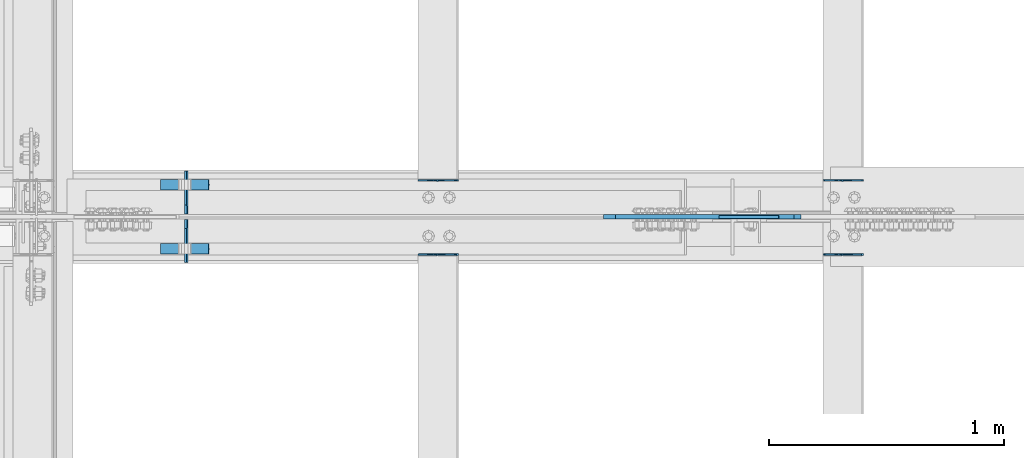
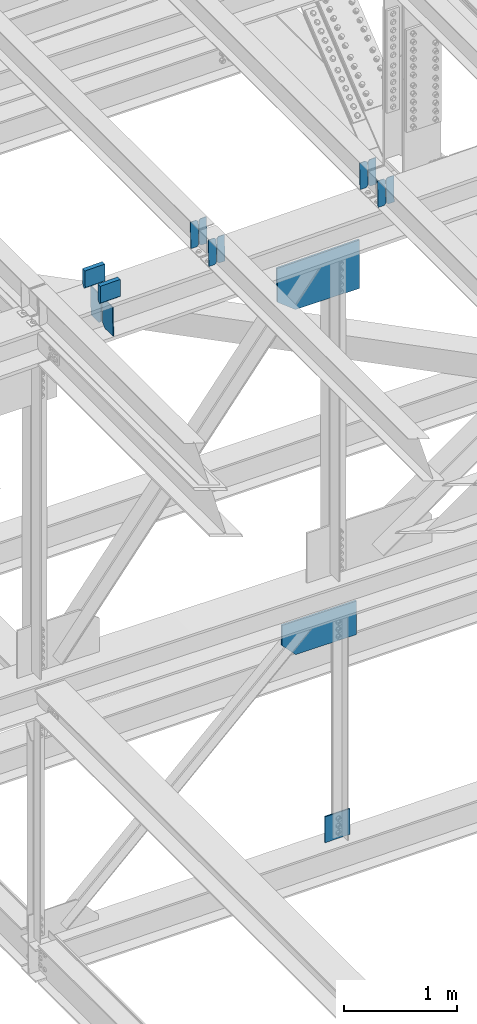
# One storey, part 3597 of 3843: 15 plates, 7 elements without a shape of their own.
"""IFC2X3 building model written with IfcOpenShell, lengths in millimetres."""

from ifc_helpers import new_model, si_unit, frame, origin_with_axes, place, context, subcontext, project, spatial, faceted_brep, material, type_object, element, aggregate, save


model = new_model("IFC2X3")

# Units and contexts
model_context = context("Model", 3, precision=1e-05, world=origin_with_axes())
body_context = subcontext(model_context, "Body", "Model", "MODEL_VIEW")
ifc_project = project(units=[si_unit("LENGTHUNIT", "METRE", prefix="MILLI"), si_unit("AREAUNIT", "SQUARE_METRE"), si_unit("VOLUMEUNIT", "CUBIC_METRE"), si_unit("MASSUNIT", "GRAM", prefix="KILO"), si_unit("TIMEUNIT", "SECOND"), si_unit("PLANEANGLEUNIT", "RADIAN"), si_unit("SOLIDANGLEUNIT", "STERADIAN"), si_unit("THERMODYNAMICTEMPERATUREUNIT", "DEGREE_CELSIUS"), si_unit("LUMINOUSINTENSITYUNIT", "LUMEN")], contexts=[model_context])

# Site, building, storey
site_placement = place(None, origin_with_axes())
site = spatial("IfcSite", under=ifc_project, at=site_placement, CompositionType="ELEMENT")
building_placement = place(site_placement, origin_with_axes())
building = spatial("IfcBuilding", under=site, at=building_placement, Name="Undefined", CompositionType="ELEMENT")
storey_placement = place(building_placement, origin_with_axes())
storey = spatial("IfcBuildingStorey", under=building, at=storey_placement, Name="Undefined", CompositionType="ELEMENT", Elevation=0.0)

# Assembly, plates
assembly_1_placement = place(storey_placement, origin_with_axes())
assembly_1 = element("IfcElementAssembly", 1, at=assembly_1_placement, inside=storey, Name="BEAM", AssemblyPlace="NOTDEFINED", PredefinedType="RIGID_FRAME")
ifc_material = material(Name="STEEL/A572-50")
plate_type_1 = type_object("IfcPlateType", PredefinedType="NOTDEFINED")
plate_1_placement = place(assembly_1_placement, frame((80549.4964783697, 50714.4613259813, 46444.4451197829), z_axis=(-0.021152098138482, -0.000624861000040255, 0.999776074075125), x_axis=(-0.999776269355722, 1.23390000256453e-05, -0.0211520940075457)))
plate_1 = element("IfcPlate", 2, at=plate_1_placement, type_object=plate_type_1, material=ifc_material, Name="PLATE", context=body_context, shape_type="Brep", body=[
    faceted_brep([(0.0, -3.17499999999927, 0.0), (6.83940015733242e-10, -3.17499999996653, 288.924999998613), (6.54836185276508e-10, 3.17500000001746, 288.924999998591), (0.0, 3.17499999999927, 0.0), (60.3250007643655, -3.17500000017753, 288.924999998606), (60.3250007643219, 3.17499999979918, 288.924999998584), (79.3750000013097, -3.17500000025029, 269.875000761494), (79.375000001266, 3.17499999972642, 269.875000761487), (79.375000000713, -3.17500000026484, 19.0499992370605), (79.3750000006985, 3.17499999971187, 19.0499992370533), (60.325000763667, -3.17500000020664, -1.45519152283669e-11), (60.3250007636234, 3.17499999977736, -3.63797880709171e-11)], [[[0, 1, 2, 3]], [[1, 4, 5, 2]], [[4, 6, 7, 5]], [[6, 8, 9, 7]], [[8, 10, 11, 9]], [[10, 0, 3, 11]], [[5, 7, 9, 11, 3, 2]], [[10, 8, 6, 4, 1, 0]]]),
])
plate_2_placement = place(assembly_1_placement, frame((80463.7906576785, 50714.4624592728, 46442.6318565363), z_axis=(-0.021152098138482, -0.000624861000040255, 0.999776074075125), x_axis=(-0.999776269355722, 1.23390000256453e-05, -0.0211520940075457)))
plate_2 = element("IfcPlate", 3, at=plate_2_placement, type_object=plate_type_1, material=ifc_material, Name="PLATE", context=body_context, shape_type="Brep", body=[
    faceted_brep([(4.36557456851006e-11, -3.17499999998836, 19.0499992370969), (6.11180439591408e-10, -3.17499999996653, 269.875000761516), (5.96628524363041e-10, 3.17500000001746, 269.875000761502), (1.45519152283669e-11, 3.17499999998836, 19.0499992370824), (19.0499992376572, -3.17500000003201, 288.924999998606), (19.0499992376281, 3.1749999999447, 288.924999998584), (79.3750000013242, -3.17500000025029, 288.924999998591), (79.3750000013097, 3.1749999997337, 288.92499999857), (79.3750000006548, -3.17500000026484, -2.18278728425503e-11), (79.3750000006403, 3.17499999969732, -2.91038304567337e-11), (19.0499992370023, -3.17500000005384, 0.0), (19.0499992369587, 3.17499999992287, -1.45519152283669e-11)], [[[0, 1, 2, 3]], [[1, 4, 5, 2]], [[4, 6, 7, 5]], [[6, 8, 9, 7]], [[8, 10, 11, 9]], [[10, 0, 3, 11]], [[5, 7, 9, 11, 3, 2]], [[10, 8, 6, 4, 1, 0]]]),
])
aggregate(assembly_1, [plate_1, plate_2])

assembly_2_placement = place(storey_placement, origin_with_axes())
assembly_2 = element("IfcElementAssembly", 4, at=assembly_2_placement, inside=storey, Name="BEAM", AssemblyPlace="NOTDEFINED", PredefinedType="RIGID_FRAME")
plate_3_placement = place(assembly_2_placement, frame((80549.4964783674, 50397.4274850828, 46443.9986155852), z_axis=(-0.0211520975879684, -0.0021646719998389, 0.999773925926638), x_axis=(-0.999776269348977, 4.5491000049241e-05, -0.0211520490073722)))
plate_3 = element("IfcPlate", 5, at=plate_3_placement, type_object=plate_type_1, material=ifc_material, Name="PLATE", context=body_context, shape_type="Brep", body=[
    faceted_brep([(0.0, -3.17499999999927, 0.0), (6.83940015733242e-10, -3.17499999996653, 288.924999998613), (6.54836185276508e-10, 3.17500000001746, 288.924999998591), (0.0, 3.17499999999927, 0.0), (60.3250007643655, -3.17500000017753, 288.924999998606), (60.3250007643219, 3.17499999979918, 288.924999998584), (79.3750000013097, -3.17500000025029, 269.875000761494), (79.375000001266, 3.17499999972642, 269.875000761487), (79.375000000713, -3.17500000026484, 19.0499992370605), (79.3750000006985, 3.17499999971187, 19.0499992370533), (60.325000763667, -3.17500000020664, -1.45519152283669e-11), (60.3250007636234, 3.17499999977736, -3.63797880709171e-11)], [[[0, 1, 2, 3]], [[1, 4, 5, 2]], [[4, 6, 7, 5]], [[6, 8, 9, 7]], [[8, 10, 11, 9]], [[10, 0, 3, 11]], [[5, 7, 9, 11, 3, 2]], [[10, 8, 6, 4, 1, 0]]]),
])
plate_4_placement = place(assembly_2_placement, frame((80463.7906576763, 50397.4314110805, 46442.1853562345), z_axis=(-0.0211520975879684, -0.0021646719998389, 0.999773925926638), x_axis=(-0.999776269348977, 4.5491000049241e-05, -0.0211520490073722)))
plate_4 = element("IfcPlate", 6, at=plate_4_placement, type_object=plate_type_1, material=ifc_material, Name="PLATE", context=body_context, shape_type="Brep", body=[
    faceted_brep([(4.36557456851006e-11, -3.17499999998836, 19.0499992370969), (6.11180439591408e-10, -3.17499999996653, 269.875000761516), (5.96628524363041e-10, 3.17500000001746, 269.875000761502), (1.45519152283669e-11, 3.17499999998836, 19.0499992370824), (19.0499992376572, -3.17500000003201, 288.924999998606), (19.0499992376281, 3.1749999999447, 288.924999998584), (79.3750000013242, -3.17500000025029, 288.924999998591), (79.3750000013097, 3.1749999997337, 288.92499999857), (79.3750000006548, -3.17500000026484, -2.18278728425503e-11), (79.3750000006403, 3.17499999969732, -2.91038304567337e-11), (19.0499992370023, -3.17500000005384, 0.0), (19.0499992369587, 3.17499999992287, -1.45519152283669e-11)], [[[0, 1, 2, 3]], [[1, 4, 5, 2]], [[4, 6, 7, 5]], [[6, 8, 9, 7]], [[8, 10, 11, 9]], [[10, 0, 3, 11]], [[5, 7, 9, 11, 3, 2]], [[10, 8, 6, 4, 1, 0]]]),
])
aggregate(assembly_2, [plate_3, plate_4])

assembly_3_placement = place(storey_placement, origin_with_axes())
assembly_3 = element("IfcElementAssembly", 7, at=assembly_3_placement, inside=storey, Name="BEAM", AssemblyPlace="NOTDEFINED", PredefinedType="RIGID_FRAME")
plate_5_placement = place(assembly_3_placement, frame((78822.2964783698, 50714.4265898309, 46411.4962019354), z_axis=(-0.021152097741724, -0.000508339000058186, 0.99977614011967), x_axis=(-0.999776269357268, 1.0337000006824e-05, -0.0211520950075907)))
plate_5 = element("IfcPlate", 8, at=plate_5_placement, type_object=plate_type_1, material=ifc_material, Name="PLATE", context=body_context, shape_type="Brep", body=[
    faceted_brep([(0.0, -3.17499999999927, 0.0), (6.83940015733242e-10, -3.17499999996653, 288.924999998613), (6.54836185276508e-10, 3.17500000001746, 288.924999998591), (0.0, 3.17499999999927, 0.0), (60.3250007643655, -3.17500000017753, 288.924999998606), (60.3250007643219, 3.17499999979918, 288.924999998584), (79.3750000013097, -3.17500000025029, 269.875000761494), (79.375000001266, 3.17499999972642, 269.875000761487), (79.375000000713, -3.17500000026484, 19.0499992370605), (79.3750000006985, 3.17499999971187, 19.0499992370533), (60.325000763667, -3.17500000020664, -1.45519152283669e-11), (60.3250007636234, 3.17499999977736, -3.63797880709171e-11)], [[[0, 1, 2, 3]], [[1, 4, 5, 2]], [[4, 6, 7, 5]], [[6, 8, 9, 7]], [[8, 10, 11, 9]], [[10, 0, 3, 11]], [[5, 7, 9, 11, 3, 2]], [[10, 8, 6, 4, 1, 0]]]),
])
plate_6_placement = place(assembly_3_placement, frame((78736.5906576785, 50714.4275117894, 46409.6829385691), z_axis=(-0.021152097741724, -0.000508339000058186, 0.99977614011967), x_axis=(-0.999776269357268, 1.0337000006824e-05, -0.0211520950075907)))
plate_6 = element("IfcPlate", 9, at=plate_6_placement, type_object=plate_type_1, material=ifc_material, Name="PLATE", context=body_context, shape_type="Brep", body=[
    faceted_brep([(4.36557456851006e-11, -3.17499999998836, 19.0499992370969), (6.11180439591408e-10, -3.17499999996653, 269.875000761516), (5.96628524363041e-10, 3.17500000001746, 269.875000761502), (1.45519152283669e-11, 3.17499999998836, 19.0499992370824), (19.0499992376572, -3.17500000003201, 288.924999998606), (19.0499992376281, 3.1749999999447, 288.924999998584), (79.3750000013242, -3.17500000025029, 288.924999998591), (79.3750000013097, 3.1749999997337, 288.92499999857), (79.3750000006548, -3.17500000026484, -2.18278728425503e-11), (79.3750000006403, 3.17499999969732, -2.91038304567337e-11), (19.0499992370023, -3.17500000005384, 0.0), (19.0499992369587, 3.17499999992287, -1.45519152283669e-11)], [[[0, 1, 2, 3]], [[1, 4, 5, 2]], [[4, 6, 7, 5]], [[6, 8, 9, 7]], [[8, 10, 11, 9]], [[10, 0, 3, 11]], [[5, 7, 9, 11, 3, 2]], [[10, 8, 6, 4, 1, 0]]]),
])
aggregate(assembly_3, [plate_5, plate_6])

assembly_4_placement = place(storey_placement, origin_with_axes())
assembly_4 = element("IfcElementAssembly", 10, at=assembly_4_placement, inside=storey, Name="BEAM", AssemblyPlace="NOTDEFINED", PredefinedType="RIGID_FRAME")
plate_7_placement = place(assembly_4_placement, frame((78822.2964783705, 50397.4508500042, 46411.0510577697), z_axis=(-0.0211520984925882, -0.00226925499999197, 0.999773693998349), x_axis=(-0.999776269336975, 4.80100000080746e-05, -0.0211520440071395)))
plate_7 = element("IfcPlate", 11, at=plate_7_placement, type_object=plate_type_1, material=ifc_material, Name="PLATE", context=body_context, shape_type="Brep", body=[
    faceted_brep([(0.0, -3.17499999999927, 0.0), (6.83940015733242e-10, -3.17499999996653, 288.924999998613), (6.54836185276508e-10, 3.17500000001746, 288.924999998591), (0.0, 3.17499999999927, 0.0), (60.3250007643655, -3.17500000017753, 288.924999998606), (60.3250007643219, 3.17499999979918, 288.924999998584), (79.3750000013097, -3.17500000025029, 269.875000761494), (79.375000001266, 3.17499999972642, 269.875000761487), (79.375000000713, -3.17500000026484, 19.0499992370605), (79.3750000006985, 3.17499999971187, 19.0499992370533), (60.325000763667, -3.17500000020664, -1.45519152283669e-11), (60.3250007636234, 3.17499999977736, -3.63797880709171e-11)], [[[0, 1, 2, 3]], [[1, 4, 5, 2]], [[4, 6, 7, 5]], [[6, 8, 9, 7]], [[8, 10, 11, 9]], [[10, 0, 3, 11]], [[5, 7, 9, 11, 3, 2]], [[10, 8, 6, 4, 1, 0]]]),
])
plate_8_placement = place(assembly_4_placement, frame((78736.5906576793, 50397.4549656826, 46409.2377988391), z_axis=(-0.0211520984925882, -0.00226925499999197, 0.999773693998349), x_axis=(-0.999776269336975, 4.80100000080746e-05, -0.0211520440071395)))
plate_8 = element("IfcPlate", 12, at=plate_8_placement, type_object=plate_type_1, material=ifc_material, Name="PLATE", context=body_context, shape_type="Brep", body=[
    faceted_brep([(4.36557456851006e-11, -3.17499999998836, 19.0499992370969), (6.11180439591408e-10, -3.17499999996653, 269.875000761516), (5.96628524363041e-10, 3.17500000001746, 269.875000761502), (1.45519152283669e-11, 3.17499999998836, 19.0499992370824), (19.0499992376572, -3.17500000003201, 288.924999998606), (19.0499992376281, 3.1749999999447, 288.924999998584), (79.3750000013242, -3.17500000025029, 288.924999998591), (79.3750000013097, 3.1749999997337, 288.92499999857), (79.3750000006548, -3.17500000026484, -2.18278728425503e-11), (79.3750000006403, 3.17499999969732, -2.91038304567337e-11), (19.0499992370023, -3.17500000005384, 0.0), (19.0499992369587, 3.17499999992287, -1.45519152283669e-11)], [[[0, 1, 2, 3]], [[1, 4, 5, 2]], [[4, 6, 7, 5]], [[6, 8, 9, 7]], [[8, 10, 11, 9]], [[10, 0, 3, 11]], [[5, 7, 9, 11, 3, 2]], [[10, 8, 6, 4, 1, 0]]]),
])
aggregate(assembly_4, [plate_7, plate_8])

assembly_5_placement = place(storey_placement, origin_with_axes())
assembly_5 = element("IfcElementAssembly", 13, at=assembly_5_placement, inside=storey, Name="BEAM", AssemblyPlace="NOTDEFINED", PredefinedType="RIGID_FRAME")
plate_type_2 = type_object("IfcPlateType", PredefinedType="NOTDEFINED")
plate_9_placement = place(assembly_5_placement, frame((77665.5774598296, 50363.1375, 46022.5066891765), z_axis=(-0.0198294219936798, 0.0, 0.99980337768153), x_axis=(0.0, 1.0, 0.0)))
plate_9 = element("IfcPlate", 14, at=plate_9_placement, type_object=plate_type_2, material=ifc_material, Name="PL", context=body_context, shape_type="Brep", body=[
    faceted_brep([(0.0, -4.76249999999709, 0.0), (0.0, -4.76249999986612, 316.896679377329), (0.0, 4.7625000001135, 316.896679377329), (0.0, 4.76249999999709, 0.0), (145.748320007318, -4.76249999986612, 316.896679377329), (145.748320007318, 4.7625000001135, 316.896679377329), (184.149999999994, -4.76249999988067, 278.494999384784), (184.149999999994, 4.76250000009895, 278.494999384777), (184.149999999994, -4.76249999998254, 38.4016799925521), (184.149999999994, 4.76249999999709, 38.4016799925594), (145.748320007318, -4.76249999999709, 7.27595761418343e-12), (145.748320007318, 4.76249999996799, 0.0)], [[[0, 1, 2, 3]], [[1, 4, 5, 2]], [[4, 6, 7, 5]], [[6, 8, 9, 7]], [[8, 10, 11, 9]], [[10, 0, 3, 11]], [[5, 7, 9, 11, 3, 2]], [[10, 8, 6, 4, 1, 0]]]),
])
plate_10_placement = place(assembly_5_placement, frame((77665.5774598296, 50570.1125, 46022.5066891765), z_axis=(-0.0198294219936798, 0.0, 0.99980337768153), x_axis=(0.0, 1.0, 0.0)))
plate_10 = element("IfcPlate", 15, at=plate_10_placement, type_object=plate_type_2, material=ifc_material, Name="PL", context=body_context, shape_type="Brep", body=[
    faceted_brep([(0.0, -4.76249999998254, 38.4016799925521), (0.0, -4.76249999988067, 278.494999384784), (0.0, 4.76250000009895, 278.494999384777), (0.0, 4.76249999999709, 38.4016799925594), (38.4016799926758, -4.76249999986612, 316.896679377329), (38.4016799926758, 4.7625000001135, 316.896679377329), (184.149999999994, -4.76249999986612, 316.896679377329), (184.149999999994, 4.7625000001135, 316.896679377329), (184.150000000009, -4.76249999999709, 0.0), (184.150000000009, 4.76249999999709, 0.0), (38.4016799926758, -4.76249999999709, 7.27595761418343e-12), (38.4016799926758, 4.76249999996799, 0.0)], [[[0, 1, 2, 3]], [[1, 4, 5, 2]], [[4, 6, 7, 5]], [[6, 8, 9, 7]], [[8, 10, 11, 9]], [[10, 0, 3, 11]], [[5, 7, 9, 11, 3, 2]], [[10, 8, 6, 4, 1, 0]]]),
])
plate_type_3 = type_object("IfcPlateType", PredefinedType="NOTDEFINED")
plate_11_placement = place(assembly_5_placement, frame((77552.4897486562, 50694.828125, 46578.5835946779), z_axis=(0.0217666070074993, 0.0, -0.999763079343992), x_axis=(0.999763079343992, 0.0, 0.0217666070075027)))
plate_11 = element("IfcPlate", 16, at=plate_11_placement, type_object=plate_type_3, material=ifc_material, Name="PLATE", context=body_context, shape_type="Brep", body=[
    faceted_brep([(203.200005058941, -22.2250000000058, -1.16415321826935e-10), (7.27595761418343e-12, -22.2250000000058, -7.27595761418343e-12), (7.27595761418343e-12, 22.2250000000058, -7.27595761418343e-12), (203.200005058941, 22.2250000000058, -1.16415321826935e-10), (203.838531807472, -22.2250000000058, 0.00187068080413155), (203.838531807472, 22.2250000000058, 0.00187068080413155), (203.310341304641, -22.2250000000058, 180.861817383484), (0.04046799018397, -22.2250000000058, 180.907287948779), (203.245434494536, 0.0133131837355904, 203.086833080139), (0.0454396034692763, 0.0133129994646879, 203.132287829787), (0.0404679902494536, 22.2250000000058, 180.907288225317), (203.310341303353, 22.2250000000058, 180.861817822159)], [[[0, 1, 2, 3]], [[4, 0, 3, 5]], [[1, 0, 4, 6, 7]], [[7, 6, 8, 9]], [[2, 1, 7, 9, 10]], [[5, 3, 2, 10, 11]], [[6, 4, 5, 11, 8]], [[10, 9, 8, 11]]]),
])
plate_12_placement = place(assembly_5_placement, frame((77552.4897486562, 50421.778125, 46578.5835946779), z_axis=(0.0217666070074993, 0.0, -0.999763079343992), x_axis=(0.999763079343992, 0.0, 0.0217666070075027)))
plate_12 = element("IfcPlate", 17, at=plate_12_placement, type_object=plate_type_3, material=ifc_material, Name="PLATE", context=body_context, shape_type="Brep", body=[
    faceted_brep([(203.200005058941, -22.2250000000058, -1.16415321826935e-10), (7.27595761418343e-12, -22.2250000000058, -7.27595761418343e-12), (7.27595761418343e-12, 22.2250000000058, -7.27595761418343e-12), (203.200005058941, 22.2250000000058, -1.16415321826935e-10), (203.838531807472, -22.2250000000058, 0.00187068080413155), (203.838531807472, 22.2250000000058, 0.00187068080413155), (203.310341304641, -22.2250000000058, 180.861817383484), (0.04046799018397, -22.2250000000058, 180.907287948779), (203.245434494536, 0.0133131837355904, 203.086833080139), (0.0454396034692763, 0.0133129994646879, 203.132287829787), (0.0404679902494536, 22.2250000000058, 180.907288225317), (203.310341303353, 22.2250000000058, 180.861817822159)], [[[0, 1, 2, 3]], [[4, 0, 3, 5]], [[1, 0, 4, 6, 7]], [[7, 6, 8, 9]], [[2, 1, 7, 9, 10]], [[5, 3, 2, 10, 11]], [[6, 4, 5, 11, 8]], [[10, 9, 8, 11]]]),
])
plate_type_4 = type_object("IfcPlateType", PredefinedType="NOTDEFINED")
plate_13_placement = place(assembly_5_placement, frame((80282.6728374061, 50558.7, 46034.1510027771), z_axis=(0.0190065849914099, 0.0, -0.999819358547815), x_axis=(-0.999819358547815, 0.0, -0.0190065849914053)))
plate_13 = element("IfcPlate", 18, at=plate_13_placement, type_object=plate_type_4, material=ifc_material, Name="PLATE", context=body_context, shape_type="Brep", body=[
    faceted_brep([(0.0, -9.52500000000146, 0.0), (9.57666129821155, -9.52500000000146, 523.612959176236), (9.57666129821155, 9.52500000000146, 523.612959176236), (0.0, 9.52500000000146, 0.0), (664.141515657349, -9.52500000000146, 511.169668844144), (664.141515657349, 9.52500000000146, 511.169668844144), (841.356334604381, -9.52500000000146, 366.764445917033), (841.356334604381, 9.52500000000146, 366.764445917033), (841.356334606258, -9.52500000000146, 4.30736690759659e-09), (841.356334606258, 9.52500000000146, 4.30736690759659e-09)], [[[0, 1, 2, 3]], [[1, 4, 5, 2]], [[4, 6, 7, 5]], [[6, 8, 9, 7]], [[8, 0, 3, 9]], [[5, 7, 9, 3, 2]], [[8, 6, 4, 1, 0]]]),
])
aggregate(assembly_5, [plate_9, plate_10, plate_11, plate_12, plate_13])

# Assembly, plate
assembly_6_placement = place(storey_placement, origin_with_axes())
assembly_6 = element("IfcElementAssembly", 19, at=assembly_6_placement, inside=storey, Name="BEAM", AssemblyPlace="NOTDEFINED", PredefinedType="RIGID_FRAME")
plate_type_5 = type_object("IfcPlateType", PredefinedType="NOTDEFINED")
plate_14_placement = place(assembly_6_placement, frame((80254.4771208274, 50558.7, 42147.4346150664), z_axis=(-0.00213745299924631, 0.0, -0.999997715644729), x_axis=(-0.999997715644729, 0.0, 0.00213745299924253)))
plate_14 = element("IfcPlate", 20, at=plate_14_placement, type_object=plate_type_5, material=ifc_material, Name="PLATE", context=body_context, shape_type="Brep", body=[
    faceted_brep([(0.0, -9.52500000000146, 0.0), (-0.770678274420789, -9.52500000000146, 361.550582194068), (-0.770678274420789, 9.52500000000146, 361.550582194068), (0.0, 9.52500000000146, 0.0), (622.092136708859, -9.52500000000146, 362.881925091126), (622.092136708859, 9.52500000000146, 362.881925091126), (762.090924623262, -9.52500000000146, 215.604704801895), (762.090924623262, 9.52500000000146, 215.604704801895), (762.090924622185, -9.52500000000146, 1.70985003933311e-09), (762.090924622185, 9.52500000000146, 1.70985003933311e-09)], [[[0, 1, 2, 3]], [[1, 4, 5, 2]], [[4, 6, 7, 5]], [[6, 8, 9, 7]], [[8, 0, 3, 9]], [[5, 7, 9, 3, 2]], [[8, 6, 4, 1, 0]]]),
])
aggregate(assembly_6, [plate_14])

assembly_7_placement = place(storey_placement, origin_with_axes())
assembly_7 = element("IfcElementAssembly", 21, at=assembly_7_placement, inside=storey, Name="BEAM", AssemblyPlace="NOTDEFINED", PredefinedType="RIGID_FRAME")
plate_type_6 = type_object("IfcPlateType", PredefinedType="NOTDEFINED")
plate_15_placement = place(assembly_7_placement, frame((80190.0414116115, 50558.7000007629, 39650.3745525031), z_axis=(-0.00804011299814736, 0.0, 0.999967677769125), x_axis=(-0.999967677769125, 0.0, -0.00804011299814515)))
plate_15 = element("IfcPlate", 22, at=plate_15_placement, type_object=plate_type_6, material=ifc_material, Name="PLATE", context=body_context, shape_type="Brep", body=[
    faceted_brep([(0.0, -6.3499999046162, 0.0), (-5.0931703299284e-10, -6.35000000000582, 278.77913354936), (-5.0931703299284e-10, 6.35000000000582, 278.77913354936), (7.27595761418343e-12, 6.3499999046162, 0.0), (253.991790192624, -6.35000000000582, 280.821322251693), (253.991790192624, 6.35000000000582, 280.821322251693), (256.249698336978, -6.35000000000582, 4.72937244921923e-10), (256.249698336978, 6.35000000000582, 4.72937244921923e-10)], [[[0, 1, 2, 3]], [[1, 4, 5, 2]], [[4, 6, 7, 5]], [[6, 0, 3, 7]], [[5, 7, 3, 2]], [[6, 4, 1, 0]]]),
])
aggregate(assembly_7, [plate_15])

save(model, "model.ifc")
